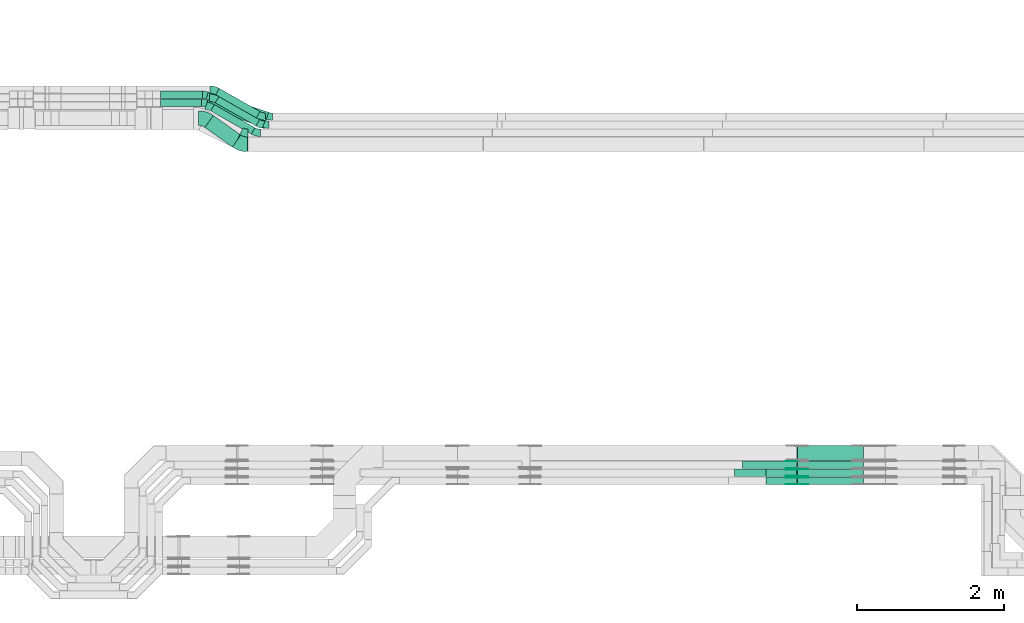
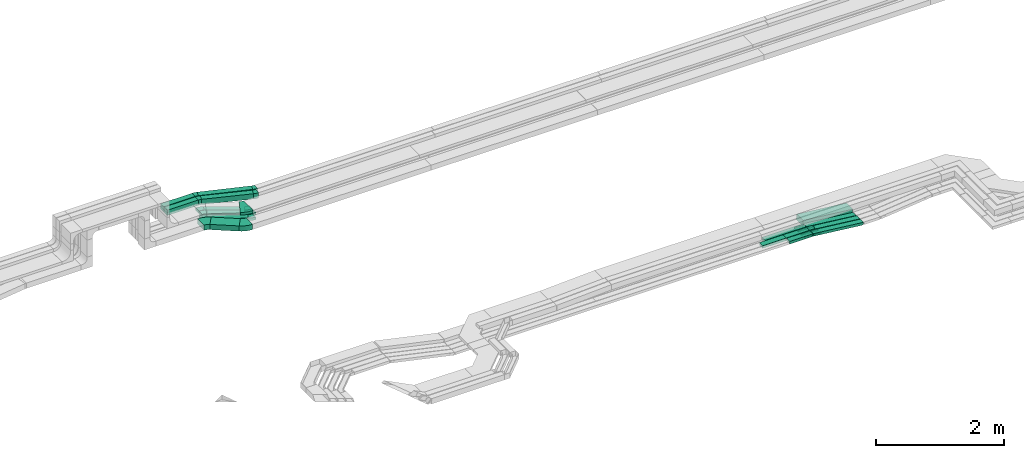
# One storey, part 18 of 33: 23 flow fittings, 16 flow segments.
"""IFC2X3 building model written with IfcOpenShell, lengths in millimetres."""

import ifcopenshell
import ifcopenshell.guid

model = None  # the IFC model being written
_history = None  # IfcOwnerHistory: only IFC2X3 demands one
_inside = {}  # id of a spatial element -> (the spatial element, [elements in it])
_under = {}  # id of a project, library or spatial element -> (it, [spatial elements below it])
_declared = {}  # id of a project -> (the project, [libraries it declares])
_typed = {}  # id of a type object -> (the type object, [elements of that type])
_made_of = {}  # id of a material, layer set ... -> (it, [elements and type objects made of it])


def new_model(schema):
    """Start an empty IFC model of exactly this schema.

    Asked for "IFC4X3", IfcOpenShell would pick the latest addendum, in which some entities
    have other attributes; the version numbers below select the first issue.
    IFC2X3 requires an IfcOwnerHistory on every rooted entity: one is made here for all.
    """
    global model, _history
    if schema == "IFC4X3":
        model = ifcopenshell.file(schema_version=(4, 3, 0, 0))
    else:
        model = ifcopenshell.file(schema=schema)
    _inside.clear()
    _under.clear()
    _declared.clear()
    _typed.clear()
    _made_of.clear()
    _history = None
    if model.schema == "IFC2X3":
        org = make("IfcOrganization", Name="unknown")
        user = make(
            "IfcPersonAndOrganization",
            ThePerson=make("IfcPerson", FamilyName="unknown"),
            TheOrganization=org,
        )
        app = make(
            "IfcApplication",
            ApplicationDeveloper=org,
            Version="unknown",
            ApplicationFullName="unknown",
            ApplicationIdentifier="unknown",
        )
        _history = make(
            "IfcOwnerHistory",
            OwningUser=user,
            OwningApplication=app,
            ChangeAction="ADDED",
            CreationDate=0,
        )
    return model


def make(cls, **values):
    """One entity of the class cls with the attributes given. An attribute that is None is left unset."""
    return model.create_entity(
        cls, **{name: value for name, value in values.items() if value is not None}
    )


def entity(cls, *values):
    """Any entity or typed value of the class cls, its attributes in the order of the schema. None: left unset."""
    e = model.create_entity(cls)
    for i, value in enumerate(values):
        if value is not None:
            e[i] = value
    return e


def rooted(cls, **values):
    """An entity with a GlobalId (a new one), such as an element, a storey or a relation."""
    return make(cls, GlobalId=ifcopenshell.guid.new(), OwnerHistory=_history, **values)


def si_unit(unit_type, name, prefix=None):
    """IfcSIUnit, for example si_unit("LENGTHUNIT", "METRE", prefix="MILLI")."""
    return make("IfcSIUnit", UnitType=unit_type, Prefix=prefix, Name=name)


def converted_unit(unit_type, name, factor, base, dimensions=None, offset=None):
    """IfcConversionBasedUnit, such as the inch: factor (a typed value) times the base unit."""
    return make(
        "IfcConversionBasedUnit"
        if offset is None
        else "IfcConversionBasedUnitWithOffset",
        ConversionOffset=offset,
        Dimensions=None
        if dimensions is None
        else entity("IfcDimensionalExponents", *dimensions),
        UnitType=unit_type,
        Name=name,
        ConversionFactor=make(
            "IfcMeasureWithUnit", ValueComponent=factor, UnitComponent=base
        ),
    )


def derived_unit(unit_type, elements):
    """IfcDerivedUnit: a product of units, each with its exponent."""
    return make(
        "IfcDerivedUnit",
        Elements=[
            make("IfcDerivedUnitElement", Unit=unit, Exponent=power)
            for unit, power in elements
        ],
        UnitType=unit_type,
    )


def assignment(units):
    """IfcUnitAssignment: the units of a project."""
    return None if units is None else make("IfcUnitAssignment", Units=units)


def point(xyz):
    """IfcCartesianPoint."""
    return None if xyz is None else make("IfcCartesianPoint", Coordinates=xyz)


def direction(xyz):
    """IfcDirection."""
    return None if xyz is None else make("IfcDirection", DirectionRatios=xyz)


def frame(location, z_axis=None, x_axis=None):
    """IfcAxis2Placement3D, a coordinate frame: its origin and axes. An axis left out is left unset."""
    return make(
        "IfcAxis2Placement3D",
        Location=point(location),
        Axis=direction(z_axis),
        RefDirection=direction(x_axis),
    )


def frame_2d(location, x_axis=None):
    """IfcAxis2Placement2D, a coordinate frame in the plane: its origin and x axis."""
    return make(
        "IfcAxis2Placement2D", Location=point(location), RefDirection=direction(x_axis)
    )


def origin():
    """The frame at (0, 0, 0) with its axes left unset."""
    return frame((0.0, 0.0, 0.0))


def origin_2d_with_axis():
    """The frame at (0, 0) in the plane with the x axis (1, 0) written out."""
    return frame_2d((0.0, 0.0), x_axis=(1.0, 0.0))


def place(relative_to, where):
    """IfcLocalPlacement: puts the frame where relative to a parent placement (None: the world)."""
    return make(
        "IfcLocalPlacement", PlacementRelTo=relative_to, RelativePlacement=where
    )


def context(
    kind, dimensions, precision=None, world=None, true_north=None, identifier=None
):
    """IfcGeometricRepresentationContext, for example the 3D "Model" context."""
    return make(
        "IfcGeometricRepresentationContext",
        ContextIdentifier=identifier,
        ContextType=kind,
        CoordinateSpaceDimension=dimensions,
        Precision=precision,
        WorldCoordinateSystem=world,
        TrueNorth=true_north,
    )


def subcontext(parent, identifier, kind, view, scale=None):
    """IfcGeometricRepresentationSubContext, for example "Body" below "Model"."""
    return make(
        "IfcGeometricRepresentationSubContext",
        ContextIdentifier=identifier,
        ContextType=kind,
        ParentContext=parent,
        TargetScale=scale,
        TargetView=view,
    )


def project(units=None, contexts=None):
    """IfcProject with its units and contexts."""
    return rooted(
        "IfcProject",
        Name="project",
        RepresentationContexts=contexts,
        UnitsInContext=assignment(units),
    )


def spatial(cls, under=None, at=None, **own):
    """A site, building, storey or space (cls), placed at a placement, below another one or the project."""
    s = rooted(cls, ObjectPlacement=at, **own)
    if under is not None:
        _under.setdefault(under.id(), (under, []))[1].append(s)
    return s


def polyline(points):
    """IfcPolyline through the points."""
    return make("IfcPolyline", Points=[point(p) for p in points])


def circle_curve(where, radius):
    """IfcCircle in the frame where."""
    return make("IfcCircle", Position=where, Radius=radius)


def parameter(value):
    """IfcParameterValue: where a trimmed curve begins or ends, as a parameter of its basis curve."""
    return model.create_entity("IfcParameterValue", value)


def trimmed(basis, trim1, trim2, sense, master):
    """IfcTrimmedCurve: the piece of a basis curve between two trims."""
    return make(
        "IfcTrimmedCurve",
        BasisCurve=basis,
        Trim1=trim1,
        Trim2=trim2,
        SenseAgreement=sense,
        MasterRepresentation=master,
    )


def segment(curve, same_sense, transition):
    """IfcCompositeCurveSegment."""
    return make(
        "IfcCompositeCurveSegment",
        Transition=transition,
        SameSense=same_sense,
        ParentCurve=curve,
    )


def composite_curve(segments, self_intersect=None):
    """IfcCompositeCurve: segments joined end to end."""
    return make("IfcCompositeCurve", Segments=segments, SelfIntersect=self_intersect)


def profile(cls, at=None, kind="AREA", **sizes):
    """A parametric profile (cls). Its sizes go by their IFC names, for example OverallWidth=200.0."""
    return make(cls, ProfileType=kind, Position=at, **sizes)


def rectangle(**sizes):
    """IfcRectangleProfileDef."""
    return profile("IfcRectangleProfileDef", **sizes)


def outline(outer, holes=None, kind="AREA"):
    """IfcArbitraryClosedProfileDef: a profile drawn as a closed curve; with holes, ...WithVoids."""
    if holes is None:
        return make("IfcArbitraryClosedProfileDef", ProfileType=kind, OuterCurve=outer)
    return make(
        "IfcArbitraryProfileDefWithVoids",
        ProfileType=kind,
        OuterCurve=outer,
        InnerCurves=holes,
    )


def extrude(swept, where, along, depth):
    """IfcExtrudedAreaSolid: the profile swept, set in the frame where, extruded along a direction by depth."""
    return make(
        "IfcExtrudedAreaSolid",
        SweptArea=swept,
        Position=where,
        ExtrudedDirection=direction(along),
        Depth=depth,
    )


def shape(context_of_items, identifier, shape_type, items):
    """IfcShapeRepresentation: the items that make up one representation, for example the "Body"."""
    return make(
        "IfcShapeRepresentation",
        ContextOfItems=context_of_items,
        RepresentationIdentifier=identifier,
        RepresentationType=shape_type,
        Items=items,
    )


def source(mapping_origin, context_of_items, identifier, shape_type, items):
    """IfcRepresentationMap: a shape defined once, which mapped items show again and again."""
    return make(
        "IfcRepresentationMap",
        MappingOrigin=mapping_origin,
        MappedRepresentation=shape(context_of_items, identifier, shape_type, items),
    )


def transform(
    local_origin,
    x_axis=None,
    y_axis=None,
    z_axis=None,
    scale=None,
    scale2=None,
    scale3=None,
    uniform=True,
):
    """IfcCartesianTransformationOperator3D, or its non-uniform kind. x_axis, y_axis, z_axis: its Axis1, 2, 3."""
    if uniform:
        return make(
            "IfcCartesianTransformationOperator3D",
            Axis1=direction(x_axis),
            Axis2=direction(y_axis),
            LocalOrigin=point(local_origin),
            Scale=scale,
            Axis3=direction(z_axis),
        )
    return make(
        "IfcCartesianTransformationOperator3DnonUniform",
        Axis1=direction(x_axis),
        Axis2=direction(y_axis),
        LocalOrigin=point(local_origin),
        Scale=scale,
        Axis3=direction(z_axis),
        Scale2=scale2,
        Scale3=scale3,
    )


def mapped(mapping_source, mapping_target):
    """IfcMappedItem: shows the shape of a source again, moved by a transform."""
    return make(
        "IfcMappedItem", MappingSource=mapping_source, MappingTarget=mapping_target
    )


def material(Name=None, Category=None):
    """IfcMaterial."""
    return make("IfcMaterial", Name=Name, Category=Category)


def made_of(thing, what):
    """Note that an element or type object is made of a material, layer set ...; save() writes the relation."""
    if what is not None:
        _made_of.setdefault(what.id(), (what, []))[1].append(thing)
    return thing


def type_object(cls, material=None, **own):
    """A type object (cls), such as IfcWallType, which elements share."""
    return made_of(rooted(cls, **own), material)


def type_shapes(of_type, sources):
    """Give a type object the sources (RepresentationMaps) that its elements show as mapped items."""
    of_type.RepresentationMaps = sources


def element(
    cls,
    number,
    at=None,
    inside=None,
    cuts=None,
    type_object=None,
    material=None,
    context=None,
    identifier="Body",
    shape_type=None,
    held_by="IfcProductDefinitionShape",
    body=None,
    shapes=None,
    **own,
):
    """One element of the class cls, such as IfcWall. Its Tag is "e" and its number.

    at: its placement. inside: the storey or other place that contains it. cuts: it is an
    opening in that element (IfcRelVoidsElement). A single representation is given by context,
    identifier, shape_type and body (its items); several are given by shapes. held_by: the class
    of the entity that holds the representations. save() writes the other relations.
    """
    e = rooted(cls, Tag="e%d" % number, ObjectPlacement=at, **own)
    if body is not None:
        shapes = [shape(context, identifier, shape_type, body)]
    if shapes is not None:
        e.Representation = make(held_by, Representations=shapes)
    if inside is not None:
        _inside.setdefault(inside.id(), (inside, []))[1].append(e)
    if cuts is not None:
        rooted(
            "IfcRelVoidsElement", RelatingBuildingElement=cuts, RelatedOpeningElement=e
        )
    if type_object is not None:
        _typed.setdefault(type_object.id(), (type_object, []))[1].append(e)
    return made_of(e, material)


def aggregate(whole, parts):
    """IfcRelAggregates: a whole, such as a stair, and the parts it consists of."""
    return rooted("IfcRelAggregates", RelatingObject=whole, RelatedObjects=parts)


def save(model, path):
    """Write the relations noted so far, then the file.

    IfcRelAggregates (storeys below a building ...), IfcRelContainedInSpatialStructure (elements
    in a storey), IfcRelDefinesByType, IfcRelAssociatesMaterial and IfcRelDeclares: one each for
    every whole, place, type object, material and project.
    """
    for whole, parts in _under.values():
        aggregate(whole, parts)
    for where, things in _inside.values():
        rooted(
            "IfcRelContainedInSpatialStructure",
            RelatedElements=things,
            RelatingStructure=where,
        )
    for kind, things in _typed.values():
        rooted("IfcRelDefinesByType", RelatedObjects=things, RelatingType=kind)
    for what, things in _made_of.values():
        rooted("IfcRelAssociatesMaterial", RelatedObjects=things, RelatingMaterial=what)
    for by, libraries in _declared.values():
        rooted("IfcRelDeclares", RelatingContext=by, RelatedDefinitions=libraries)
    model.write(path)


model = new_model("IFC2X3")

# Units and contexts
model_context = context("Model", 3, precision=0.01, world=origin(), true_north=direction((6.12303176911189e-17, 1.0)))
body_context = subcontext(model_context, "Body", "Model", "MODEL_VIEW")
ifc_project = project(units=[si_unit("LENGTHUNIT", "METRE", prefix="MILLI"), si_unit("AREAUNIT", "SQUARE_METRE"), si_unit("VOLUMEUNIT", "CUBIC_METRE"), converted_unit("PLANEANGLEUNIT", "DEGREE", entity("IfcRatioMeasure", 0.0174532925199433), si_unit("PLANEANGLEUNIT", "RADIAN"), dimensions=[0, 0, 0, 0, 0, 0, 0]), si_unit("MASSUNIT", "GRAM", prefix="KILO"), derived_unit("MASSDENSITYUNIT", [(si_unit("MASSUNIT", "GRAM", prefix="KILO"), 1), (si_unit("LENGTHUNIT", "METRE"), -3)]), derived_unit("MOMENTOFINERTIAUNIT", [(si_unit("LENGTHUNIT", "METRE"), 4)]), si_unit("TIMEUNIT", "SECOND"), si_unit("FREQUENCYUNIT", "HERTZ"), si_unit("THERMODYNAMICTEMPERATUREUNIT", "DEGREE_CELSIUS"), derived_unit("THERMALTRANSMITTANCEUNIT", [(si_unit("MASSUNIT", "GRAM", prefix="KILO"), 1), (si_unit("THERMODYNAMICTEMPERATUREUNIT", "KELVIN"), -1), (si_unit("TIMEUNIT", "SECOND"), -3)]), derived_unit("VOLUMETRICFLOWRATEUNIT", [(si_unit("LENGTHUNIT", "METRE"), 3), (si_unit("TIMEUNIT", "SECOND"), -1)]), derived_unit("MASSFLOWRATEUNIT", [(si_unit("MASSUNIT", "GRAM", prefix="KILO"), 1), (si_unit("TIMEUNIT", "SECOND"), -1)]), derived_unit("ROTATIONALFREQUENCYUNIT", [(si_unit("TIMEUNIT", "SECOND"), -1)]), si_unit("ELECTRICCURRENTUNIT", "AMPERE"), si_unit("ELECTRICVOLTAGEUNIT", "VOLT"), si_unit("POWERUNIT", "WATT"), si_unit("FORCEUNIT", "NEWTON", prefix="KILO"), si_unit("ILLUMINANCEUNIT", "LUX"), si_unit("LUMINOUSFLUXUNIT", "LUMEN"), si_unit("LUMINOUSINTENSITYUNIT", "CANDELA"), derived_unit("USERDEFINED", [(si_unit("MASSUNIT", "GRAM", prefix="KILO"), -1), (si_unit("LENGTHUNIT", "METRE"), -2), (si_unit("TIMEUNIT", "SECOND"), 3), (si_unit("LUMINOUSFLUXUNIT", "LUMEN"), 1)]), derived_unit("LINEARVELOCITYUNIT", [(si_unit("LENGTHUNIT", "METRE"), 1), (si_unit("TIMEUNIT", "SECOND"), -1)]), si_unit("PRESSUREUNIT", "PASCAL"), derived_unit("USERDEFINED", [(si_unit("LENGTHUNIT", "METRE"), -2), (si_unit("MASSUNIT", "GRAM", prefix="KILO"), 1), (si_unit("TIMEUNIT", "SECOND"), -2)]), derived_unit("LINEARFORCEUNIT", [(si_unit("MASSUNIT", "GRAM", prefix="KILO"), 1), (si_unit("LENGTHUNIT", "METRE"), 1), (si_unit("TIMEUNIT", "SECOND"), -2), (si_unit("LENGTHUNIT", "METRE"), -1)]), derived_unit("PLANARFORCEUNIT", [(si_unit("MASSUNIT", "GRAM", prefix="KILO"), 1), (si_unit("LENGTHUNIT", "METRE"), 1), (si_unit("TIMEUNIT", "SECOND"), -2), (si_unit("LENGTHUNIT", "METRE"), -2)])], contexts=[model_context])

# Site, building, storey
site_placement = place(None, frame((0.0, -0.00077364408347762, 0.0)))
site = spatial("IfcSite", under=ifc_project, at=site_placement, CompositionType="ELEMENT")
building_placement = place(site_placement, origin())
building = spatial("IfcBuilding", under=site, at=building_placement, CompositionType="ELEMENT")
storey_placement = place(building_placement, frame((0.0, 0.0, 8100.0)))
storey = spatial("IfcBuildingStorey", under=building, at=storey_placement, CompositionType="ELEMENT", Elevation=8100.0)

# Flow segments
cable_carrier_segment_type = type_object("IfcCableCarrierSegmentType", PredefinedType="CABLETRAYSEGMENT")
flow_segment_1_placement = place(storey_placement, frame((39414.2553602729, 9864.99855346682, 2544.92549664435)))
element("IfcFlowSegment", 1, at=flow_segment_1_placement, inside=storey, type_object=cable_carrier_segment_type, context=body_context, shape_type="SweptSolid", body=[
    extrude(rectangle(XDim=734.864056960746, YDim=99.9999999999989, at=frame_2d((4.32009983342141e-12, 0.0), x_axis=(1.0, 0.0))), frame((367.432028480377, 50.0, 0.0)), (0.0, 0.0, 1.0), 50.0000000000016),
])
flow_segment_2_placement = place(storey_placement, frame((39304.2553602729, 9754.99855346681, 2546.31908538351)))
element("IfcFlowSegment", 2, at=flow_segment_2_placement, inside=storey, type_object=cable_carrier_segment_type, context=body_context, shape_type="SweptSolid", body=[
    extrude(rectangle(XDim=948.992857325044, YDim=99.9999999999989, at=frame_2d((-4.32009983342141e-12, 0.0), x_axis=(1.0, 0.0))), frame((474.496428662526, 50.0, 0.0)), (0.0, 0.0, 1.0), 50.0000000000016),
])
flow_segment_3_placement = place(storey_placement, frame((32094.1810027056, 14239.3490417928, 2548.87698397102)))
element("IfcFlowSegment", 3, at=flow_segment_3_placement, inside=storey, type_object=cable_carrier_segment_type, context=body_context, shape_type="SweptSolid", body=[
    extrude(rectangle(XDim=458.510292454723, YDim=200.000000000002, at=frame_2d((-1.76214598468505e-12, -1.25766064229538e-12), x_axis=(1.0, 0.0))), frame((244.909500939085, 214.039689258386, 0.0), z_axis=(0.0, 0.0, 1.0), x_axis=(-0.816364917109081, 0.577536424923557, 0.0)), (0.0, 0.0, 1.0), 99.9999999999989),
])
flow_segment_4_placement = place(storey_placement, frame((32235.1195390876, 14525.3656413056, 2548.34838425104)))
element("IfcFlowSegment", 4, at=flow_segment_4_placement, inside=storey, type_object=cable_carrier_segment_type, context=body_context, shape_type="SweptSolid", body=[
    extrude(rectangle(XDim=637.297455532549, YDim=100.000000000004, at=frame_2d((5.40012479177676e-13, -9.48574552239734e-13), x_axis=(1.0, 0.0))), frame((301.790593880873, 200.802099136024, 0.0), z_axis=(0.0, 0.0, 1.0), x_axis=(-0.869625227484752, 0.493712430187952, 0.0)), (0.0, 0.0, 1.0), 50.0000000000016),
])
flow_segment_5_placement = place(storey_placement, frame((32172.6692264652, 14415.3656413056, 2548.879926104)))
element("IfcFlowSegment", 5, at=flow_segment_5_placement, inside=storey, type_object=cable_carrier_segment_type, context=body_context, shape_type="SweptSolid", body=[
    extrude(rectangle(XDim=637.297455532608, YDim=99.9999999999995, at=frame_2d((5.40012479177676e-13, -9.41469124882133e-13), x_axis=(1.0, 0.0))), frame((301.790593880899, 200.802099136031, 0.0), z_axis=(0.0, 0.0, 1.0), x_axis=(-0.869625227484766, 0.493712430187927, 0.0)), (0.0, 0.0, 1.0), 50.0000000000016),
])
flow_segment_6_placement = place(storey_placement, frame((32240.5963756525, 14635.3656413056, 2548.86724903677)))
element("IfcFlowSegment", 6, at=flow_segment_6_placement, inside=storey, type_object=cable_carrier_segment_type, context=body_context, shape_type="SweptSolid", body=[
    extrude(rectangle(XDim=637.297455532466, YDim=100.0, at=frame_2d((1.90425453183707e-12, 1.07647224467655e-12), x_axis=(1.0, 0.0))), frame((301.790593880838, 200.802099136011, 0.0), z_axis=(0.0, 0.0, 1.0), x_axis=(-0.869625227484736, 0.49371243018798, 0.0)), (0.0, 0.0, 1.0), 50.0000000000016),
])
flow_segment_7_placement = place(storey_placement, frame((32109.5124104278, 14615.6591121141, 2855.0)))
element("IfcFlowSegment", 7, at=flow_segment_7_placement, inside=storey, type_object=cable_carrier_segment_type, context=body_context, shape_type="SweptSolid", body=[
    extrude(rectangle(XDim=865.944698440222, YDim=100.000000000001, at=frame_2d((2.41584530158434e-12, -3.41060513164848e-13), x_axis=(1.0, 0.0))), frame((426.300961317753, 185.508628327534, 0.0), z_axis=(0.0, 0.0, 1.0), x_axis=(0.947752520609184, -0.319006519806318, 0.0)), (0.0, 0.0, 1.0), 99.9999999999989),
])
flow_segment_8_placement = place(storey_placement, frame((31491.4130823037, 14900.0572451367, 2855.0)))
element("IfcFlowSegment", 8, at=flow_segment_8_placement, inside=storey, type_object=cable_carrier_segment_type, context=body_context, shape_type="SweptSolid", body=[
    extrude(rectangle(XDim=568.300597632481, YDim=99.9999999999989, at=frame_2d((0.0, 1.08357767203415e-12), x_axis=(1.0, 0.0))), frame((284.15029881624, 50.0, 0.0)), (0.0, 0.0, 1.0), 99.9999999999989),
])
flow_segment_9_placement = place(storey_placement, frame((32102.1575916921, 14506.8072977071, 2855.0)))
element("IfcFlowSegment", 9, at=flow_segment_9_placement, inside=storey, type_object=cable_carrier_segment_type, context=body_context, shape_type="SweptSolid", body=[
    extrude(rectangle(XDim=826.032338291808, YDim=99.9999999999999, at=origin_2d_with_axis()), frame((406.171515449329, 184.36044273458, 0.0), z_axis=(0.0, 0.0, 1.0), x_axis=(0.943212511924906, -0.332189941672396, 0.0)), (0.0, 0.0, 1.0), 99.9999999999989),
])
flow_segment_10_placement = place(storey_placement, frame((31491.4130823037, 14790.0572451367, 2855.0)))
element("IfcFlowSegment", 10, at=flow_segment_10_placement, inside=storey, type_object=cable_carrier_segment_type, context=body_context, shape_type="SweptSolid", body=[
    extrude(rectangle(XDim=558.972805625544, YDim=99.9999999999989, at=frame_2d((0.0, -1.08357767203415e-12), x_axis=(1.0, 0.0))), frame((279.486402812772, 50.0, 0.0)), (0.0, 0.0, 1.0), 99.9999999999989),
])
flow_segment_11_placement = place(storey_placement, frame((40151.5523091819, 9644.99855346679, 2447.10523946025)))
element("IfcFlowSegment", 11, at=flow_segment_11_placement, inside=storey, type_object=cable_carrier_segment_type, context=body_context, shape_type="SweptSolid", body=[
    extrude(rectangle(XDim=50.0000000000012, YDim=100.000000000001, at=origin_2d_with_axis()), frame((2.74331759634265, 50.0, 124.2429877633), z_axis=(0.993961132894519, 0.0, -0.109732703853703), x_axis=(0.109732703853703, 0.0, 0.993961132894519)), (0.0, 0.0, 1.0), 905.782469130237),
])
flow_segment_12_placement = place(storey_placement, frame((39730.3894172285, 9644.99855346679, 2546.63308707346)))
element("IfcFlowSegment", 12, at=flow_segment_12_placement, inside=storey, type_object=cable_carrier_segment_type, context=body_context, shape_type="SweptSolid", body=[
    extrude(rectangle(XDim=418.730000005077, YDim=100.000000000001, at=frame_2d((-4.33431068813661e-12, 0.0), x_axis=(1.0, 0.0))), frame((209.365000002543, 50.0, 0.0), z_axis=(0.0, 0.0, 1.0), x_axis=(-1.0, 0.0, 0.0)), (0.0, 0.0, 1.0), 50.0000000000016),
])
flow_segment_13_placement = place(storey_placement, frame((40151.5145270794, 9754.99855346682, 2446.75883726185)))
element("IfcFlowSegment", 13, at=flow_segment_13_placement, inside=storey, type_object=cable_carrier_segment_type, context=body_context, shape_type="SweptSolid", body=[
    extrude(rectangle(XDim=50.0000000000012, YDim=99.9999999999989, at=origin_2d_with_axis()), frame((2.74331759634265, 50.0, 124.247158884456), z_axis=(0.993961132894519, 0.0, -0.109732703853703), x_axis=(0.109732703853703, 0.0, 0.993961132894519)), (0.0, 0.0, 1.0), 905.820480780093),
])
flow_segment_14_placement = place(storey_placement, frame((39730.3894172285, 9754.99855346682, 2546.29085599621)))
element("IfcFlowSegment", 14, at=flow_segment_14_placement, inside=storey, type_object=cable_carrier_segment_type, context=body_context, shape_type="SweptSolid", body=[
    extrude(rectangle(XDim=418.692217902529, YDim=99.9999999999989, at=frame_2d((-4.33431068813661e-12, 0.0), x_axis=(1.0, 0.0))), frame((209.346108951269, 50.0, 0.0), z_axis=(0.0, 0.0, 1.0), x_axis=(-1.0, 0.0, 0.0)), (0.0, 0.0, 1.0), 50.0000000000038),
])
flow_segment_15_placement = place(storey_placement, frame((40151.5523091819, 9864.99855346682, 2445.41821058217)))
element("IfcFlowSegment", 15, at=flow_segment_15_placement, inside=storey, type_object=cable_carrier_segment_type, context=body_context, shape_type="SweptSolid", body=[
    extrude(rectangle(XDim=50.0000000000012, YDim=99.9999999999989, at=origin_2d_with_axis()), frame((2.74331759633399, 50.0, 124.222426212274), z_axis=(0.993961132894519, 0.0, -0.109732703853703), x_axis=(0.109732703853703, 0.0, 0.993961132894519)), (0.0, 0.0, 1.0), 905.595090615417),
])
flow_segment_16_placement = place(storey_placement, frame((40151.5684003383, 9974.9985534668, 2447.844082236)))
element("IfcFlowSegment", 16, at=flow_segment_16_placement, inside=storey, type_object=cable_carrier_segment_type, context=body_context, shape_type="SweptSolid", body=[
    extrude(rectangle(XDim=99.9999999999982, YDim=200.000000000002, at=origin_2d_with_axis()), frame((5.48663519269396, 100.0, 148.484518447362), z_axis=(0.993961132894518, 0.0, -0.109732703853708), x_axis=(0.109732703853708, 0.0, 0.993961132894518)), (0.0, 0.0, 1.0), 900.246310655869),
])

# Flow fittings
ifc_material_1 = material()
cable_carrier_fitting_type_1 = type_object("IfcCableCarrierFittingType", Name="470_DKC_S5_Variable Angle Elbow 0-45:-", PredefinedType="NOTDEFINED", material=ifc_material_1)
shared_shape_1 = source(origin(), body_context, "Body", "SweptSolid", [
    extrude(outline(composite_curve([segment(polyline([(-67.6616049684268, -165.75060662875), (-66.6616049684255, -165.75060662875)]), True, "CONTINUOUS"), segment(trimmed(circle_curve(frame_2d((-66.6616049684336, 284.24939337125), x_axis=(0.0, -1.0)), 450.0), [parameter(0.0)], [parameter(26.3967564439115)], True, "PARAMETER"), True, "CONTINUOUS"), segment(polyline([(133.401407239414, -118.83222509618), (134.297144169341, -118.387640624607)]), True, "CONTINUOUS"), segment(polyline([(134.297144169341, -118.387640624607), (0.921802697443936, 150.33343835368)]), True, "CONTINUOUS"), segment(polyline([(0.921802697443919, 150.33343835368), (0.0260657675154811, 149.888853882107)]), True, "CONTINUOUS"), segment(trimmed(circle_curve(frame_2d((-66.6616049684336, 284.24939337125), x_axis=(0.0, -1.0)), 150.0), [parameter(0.0)], [parameter(26.3967564439115)], True, "PARAMETER"), False, "CONTINUOUS"), segment(polyline([(-66.6616049684306, 134.24939337125), (-67.6616049684319, 134.24939337125)]), True, "CONTINUOUS"), segment(polyline([(-67.6616049684319, 134.24939337125), (-67.6616049684268, -165.75060662875)]), True, "CONTINUOUS")], self_intersect=False)), frame((-3.69380108306741, 15.7506066287408, -25.0)), (0.0, 0.0, 1.0), 49.999999999999),
])
type_shapes(cable_carrier_fitting_type_1, [shared_shape_1])
flow_fitting_placement = place(storey_placement, frame((32612.1430823088, 14332.2782357472, 2879.49733895749), z_axis=(0.0, 0.0, 1.0), x_axis=(0.895736929927626, -0.444584471572987, 0.0)))
element("IfcFlowFitting", 17, at=flow_fitting_placement, inside=storey, type_object=cable_carrier_fitting_type_1, material=ifc_material_1, Name="470_DKC_S5_Variable Angle Elbow 0-45:-", ObjectType="470_DKC_S5_Variable Angle Elbow 0-45:-", context=body_context, shape_type="MappedRepresentation", body=[
    mapped(shared_shape_1, transform((0.0, 0.0, 0.0), scale=1.0)),
])
cable_carrier_fitting_type_2 = type_object("IfcCableCarrierFittingType", Name="470_DKC_S5_Variable Angle Elbow 0-45:-", PredefinedType="NOTDEFINED", material=ifc_material_1)
shared_shape_2 = source(origin(), body_context, "Body", "SweptSolid", [
    extrude(outline(composite_curve([segment(polyline([(-73.1461443447185, -123.098769467593), (-72.1461443447173, -123.098769467593)]), True, "CONTINUOUS"), segment(trimmed(circle_curve(frame_2d((-72.1461443447177, 226.901230532407), x_axis=(0.0, -1.0)), 350.0), [parameter(0.0)], [parameter(35.2774537887441)], True, "PARAMETER"), True, "CONTINUOUS"), segment(polyline([(129.991604378515, -58.8264904557794), (130.807969295625, -58.2489540308556)]), True, "CONTINUOUS"), segment(polyline([(130.807969295625, -58.2489540308556), (15.3006843109194, 105.024029390965)]), True, "CONTINUOUS"), segment(polyline([(15.3006843109194, 105.024029390965), (14.4843193938107, 104.446492966041)]), True, "CONTINUOUS"), segment(trimmed(circle_curve(frame_2d((-72.1461443447177, 226.901230532407), x_axis=(0.0, -1.0)), 150.0), [parameter(0.0)], [parameter(35.2774537887441)], True, "PARAMETER"), False, "CONTINUOUS"), segment(polyline([(-72.1461443447173, 76.9012305324071), (-73.1461443447185, 76.9012305324071)]), True, "CONTINUOUS"), segment(polyline([(-73.1461443447185, 76.9012305324071), (-73.1461443447185, -123.098769467593)]), True, "CONTINUOUS")], self_intersect=False)), frame((-7.34454878134336, 23.0987694675847, -50.0)), (0.0, 0.0, 1.0), 100.0),
])
type_shapes(cable_carrier_fitting_type_2, [shared_shape_2])
for number, where, z_axis, x_axis, name in (
    (18, (32591.9561401134, 14274.499226356, 2598.87698397102), (0.0, 0.0, 1.0), (0.816364917109106, -0.577536424923522, 0.0), "470_DKC_S5_Variable Angle Elbow 0-45:-"),
    (19, (32086.2248671761, 14632.2782357463, 2598.87698397102), (0.0, 0.0, 1.0), (-0.81636491710906, 0.577536424923586, 0.0), "470_DKC_S5_Variable Angle Elbow 0-45:-"),
):
    element("IfcFlowFitting", number, at=place(storey_placement, frame(where, z_axis=z_axis, x_axis=x_axis)), inside=storey, type_object=cable_carrier_fitting_type_2, material=ifc_material_1, Name=name, ObjectType="470_DKC_S5_Variable Angle Elbow 0-45:-", context=body_context, shape_type="MappedRepresentation", body=[
        mapped(shared_shape_2, transform((0.0, 0.0, 0.0), scale=1.0)),
    ])
cable_carrier_fitting_type_3 = type_object("IfcCableCarrierFittingType", Name="470_DKC_S5_Variable Angle Elbow 0-45:-", PredefinedType="NOTDEFINED", material=ifc_material_1)
shared_shape_3 = source(origin(), body_context, "Body", "SweptSolid", [
    extrude(outline(composite_curve([segment(polyline([(-50.3386493256676, -63.160905359072), (-49.3386493256662, -63.160905359072)]), True, "CONTINUOUS"), segment(trimmed(circle_curve(frame_2d((-49.3386493256667, 186.839094640928), x_axis=(0.0, -1.0)), 250.0), [parameter(0.0)], [parameter(29.5848823129969)], True, "PARAMETER"), True, "CONTINUOUS"), segment(polyline([(74.089458221322, -30.5672122302595), (74.959083448807, -30.0734998000714)]), True, "CONTINUOUS"), segment(polyline([(74.959083448807, -30.0734998000715), (25.5878404300111, 56.8890229484032)]), True, "CONTINUOUS"), segment(polyline([(25.5878404300111, 56.8890229484032), (24.7182152025265, 56.3953105182154)]), True, "CONTINUOUS"), segment(trimmed(circle_curve(frame_2d((-49.3386493256667, 186.839094640928), x_axis=(0.0, -1.0)), 150.0), [parameter(0.0)], [parameter(29.5848823129969)], True, "PARAMETER"), False, "CONTINUOUS"), segment(polyline([(-49.3386493256662, 36.8390946409279), (-50.3386493256676, 36.8390946409279)]), True, "CONTINUOUS"), segment(polyline([(-50.3386493256676, 36.8390946409279), (-50.3386493256676, -63.160905359072)]), True, "CONTINUOUS")], self_intersect=False)), frame((-3.47540377224392, 13.1609053590639, -25.0)), (0.0, 0.0, 1.0), 50.0),
])
type_shapes(cable_carrier_fitting_type_3, [shared_shape_3])
for number, where, z_axis, x_axis, name in (
    (20, (32213.0071024299, 14910.0572451366, 2573.34838425104), (0.0, 0.0, 1.0), (-0.869625227484751, 0.493712430187954, 0.0), "470_DKC_S5_Variable Angle Elbow 0-45:-"),
    (21, (32150.5567898075, 14800.0572451366, 2573.87992610401), (0.0, 0.0, 1.0), (-0.869625227484763, 0.493712430187932, 0.0), "470_DKC_S5_Variable Angle Elbow 0-45:-"),
    (22, (32798.3628508848, 14432.2782357466, 2573.87992610401), (0.0, 0.0, 1.0), (0.869625227484763, -0.493712430187932, 0.0), "470_DKC_S5_Variable Angle Elbow 0-45:-"),
    (23, (32866.2900000719, 14652.2782357466, 2573.86724903678), (0.0, 0.0, 1.0), (0.869625227484745, -0.493712430187964, 0.0), "470_DKC_S5_Variable Angle Elbow 0-45:-"),
    (24, (32218.4839389948, 15020.0572451366, 2573.86724903678), (0.0, 0.0, 1.0), (-0.869625227484732, 0.493712430187987, 0.0), "470_DKC_S5_Variable Angle Elbow 0-45:-"),
    (25, (32860.8131635071, 14542.2782357466, 2573.34838425104), (0.0, 0.0, 1.0), (0.869625227484747, -0.49371243018796, 0.0), "470_DKC_S5_Variable Angle Elbow 0-45:-"),
):
    element("IfcFlowFitting", number, at=place(storey_placement, frame(where, z_axis=z_axis, x_axis=x_axis)), inside=storey, type_object=cable_carrier_fitting_type_3, material=ifc_material_1, Name=name, ObjectType="470_DKC_S5_Variable Angle Elbow 0-45:-", context=body_context, shape_type="MappedRepresentation", body=[
        mapped(shared_shape_3, transform((0.0, 0.0, 0.0), scale=1.0)),
    ])
cable_carrier_fitting_type_4 = type_object("IfcCableCarrierFittingType", Name="470_DKC_S5_Variable Angle Elbow 0-45:-", PredefinedType="NOTDEFINED", material=ifc_material_1)
shared_shape_4 = source(origin(), body_context, "Body", "SweptSolid", [
    extrude(outline(composite_curve([segment(polyline([(-32.8875901107843, -55.3044995690334), (-31.887590110783, -55.3044995690334)]), True, "CONTINUOUS"), segment(trimmed(circle_curve(frame_2d((-31.8875901107856, 194.695500430966), x_axis=(0.0, -1.0)), 250.0), [parameter(0.0)], [parameter(18.6028540575066)], True, "PARAMETER"), True, "CONTINUOUS"), segment(polyline([(47.8640398407955, -42.2426297213288), (48.8117923614045, -41.9236232015225)]), True, "CONTINUOUS"), segment(polyline([(48.8117923614045, -41.9236232015225), (16.9111403807724, 52.8516288593956)]), True, "CONTINUOUS"), segment(polyline([(16.9111403807724, 52.8516288593956), (15.963387860163, 52.5326223395892)]), True, "CONTINUOUS"), segment(trimmed(circle_curve(frame_2d((-31.8875901107856, 194.695500430966), x_axis=(0.0, -1.0)), 150.0), [parameter(0.0)], [parameter(18.6028540575066)], True, "PARAMETER"), False, "CONTINUOUS"), segment(polyline([(-31.8875901107839, 44.6955004309665), (-32.8875901107852, 44.6955004309665)]), True, "CONTINUOUS"), segment(polyline([(-32.8875901107852, 44.6955004309665), (-32.8875901107843, -55.3044995690334)]), True, "CONTINUOUS")], self_intersect=False)), frame((-0.868780776257499, 5.30449956902505, -50.0)), (0.0, 0.0, 1.0), 100.0),
])
type_shapes(cable_carrier_fitting_type_4, [shared_shape_4])
for number, where, z_axis, x_axis, name in (
    (26, (32093.4700508233, 14950.0572451367, 2905.0), (0.0, 0.0, 1.0), (-0.947752520609185, 0.319006519806315, 0.0), "470_DKC_S5_Variable Angle Elbow 0-45:-"),
    (27, (32978.1566926678, 14652.2782357467, 2905.0), (0.0, 0.0, 1.0), (0.947752520609181, -0.319006519806326, 0.0), "470_DKC_S5_Variable Angle Elbow 0-45:-"),
):
    element("IfcFlowFitting", number, at=place(storey_placement, frame(where, z_axis=z_axis, x_axis=x_axis)), inside=storey, type_object=cable_carrier_fitting_type_4, material=ifc_material_1, Name=name, ObjectType="470_DKC_S5_Variable Angle Elbow 0-45:-", context=body_context, shape_type="MappedRepresentation", body=[
        mapped(shared_shape_4, transform((0.0, 0.0, 0.0), scale=1.0)),
    ])
cable_carrier_fitting_type_5 = type_object("IfcCableCarrierFittingType", Name="470_DKC_S5_Variable Angle Elbow 0-45:-", PredefinedType="NOTDEFINED", material=ifc_material_1)
shared_shape_5 = source(origin(), body_context, "Body", "SweptSolid", [
    extrude(outline(composite_curve([segment(polyline([(-34.2047972952214, -55.7617962929279), (-33.2047972952201, -55.7617962929279)]), True, "CONTINUOUS"), segment(trimmed(circle_curve(frame_2d((-33.2047972952227, 194.238203707072), x_axis=(0.0, -1.0)), 250.0), [parameter(0.0)], [parameter(19.4017500514484)], True, "PARAMETER"), True, "CONTINUOUS"), segment(polyline([(49.8426881228788, -41.5649242741534), (50.7859006348036, -41.232734332481)]), True, "CONTINUOUS"), segment(polyline([(50.7859006348036, -41.232734332481), (17.5669064675632, 53.0885168600091)]), True, "CONTINUOUS"), segment(polyline([(17.5669064675632, 53.0885168600091), (16.6236939556382, 52.7563269183367)]), True, "CONTINUOUS"), segment(trimmed(circle_curve(frame_2d((-33.2047972952227, 194.238203707072), x_axis=(0.0, -1.0)), 150.0), [parameter(0.0)], [parameter(19.4017500514484)], True, "PARAMETER"), False, "CONTINUOUS"), segment(polyline([(-33.204797295221, 44.238203707072), (-34.2047972952223, 44.238203707072)]), True, "CONTINUOUS"), segment(polyline([(-34.2047972952223, 44.238203707072), (-34.2047972952214, -55.7617962929279)]), True, "CONTINUOUS")], self_intersect=False)), frame((-0.984972442649047, 5.76179629291953, -50.0)), (0.0, 0.0, 1.0), 100.0),
])
type_shapes(cable_carrier_fitting_type_5, [shared_shape_5])
for number, where, z_axis, x_axis, name in (
    (28, (32085.5756576672, 14840.0572451367, 2905.0), (0.0, 0.0, 1.0), (-0.943212511924905, 0.332189941672396, 0.0), "470_DKC_S5_Variable Angle Elbow 0-45:-"),
    (29, (32931.0825566156, 14542.2782357467, 2905.0), (0.0, 0.0, 1.0), (0.943212511924902, -0.332189941672405, 0.0), "470_DKC_S5_Variable Angle Elbow 0-45:-"),
):
    element("IfcFlowFitting", number, at=place(storey_placement, frame(where, z_axis=z_axis, x_axis=x_axis)), inside=storey, type_object=cable_carrier_fitting_type_5, material=ifc_material_1, Name=name, ObjectType="470_DKC_S5_Variable Angle Elbow 0-45:-", context=body_context, shape_type="MappedRepresentation", body=[
        mapped(shared_shape_5, transform((0.0, 0.0, 0.0), scale=1.0)),
    ])
ifc_material_2 = material(Name="G")
cable_carrier_fitting_type_6 = type_object("IfcCableCarrierFittingType", PredefinedType="NOTDEFINED", material=ifc_material_2)
shared_shape_6 = source(origin(), body_context, "Body", "SweptSolid", [
    extrude(outline(composite_curve([segment(trimmed(circle_curve(frame_2d((-44.5901162790698, 0.0), x_axis=(1.0, 0.0)), 12.5), [parameter(90.0000000000007)], [parameter(270.0)], True, "PARAMETER"), True, "CONTINUOUS"), segment(polyline([(-44.5901162790697, -12.5), (-33.0901162790698, -12.5)]), True, "CONTINUOUS"), segment(polyline([(-33.0901162790698, -12.5), (-31.2296511627907, -14.5)]), True, "CONTINUOUS"), segment(polyline([(-31.2296511627907, -14.5), (108.90988372093, -14.5)]), True, "CONTINUOUS"), segment(polyline([(108.90988372093, -14.5), (108.90988372093, 14.5)]), True, "CONTINUOUS"), segment(polyline([(108.90988372093, 14.5), (-31.2296511627907, 14.5)]), True, "CONTINUOUS"), segment(polyline([(-31.2296511627907, 14.5), (-33.0901162790698, 12.5)]), True, "CONTINUOUS"), segment(polyline([(-33.0901162790698, 12.5), (-44.5901162790699, 12.5)]), True, "CONTINUOUS")], self_intersect=False)), frame((44.5901162790698, 0.0, 0.0), z_axis=(0.0, 0.0, -1.0), x_axis=(1.0, 0.0, 0.0)), (0.0, 0.0, -1.0), 2.0),
])
type_shapes(cable_carrier_fitting_type_6, [shared_shape_6])
for number, where, z_axis, x_axis in (
    (30, (40151.7153602835, 9740.45855347695, 2571.63308707348), (0.0, 1.0, 0.0), (0.993961132894515, 0.0, -0.10973270385374)),
    (31, (40151.6775781809, 9850.45855347697, 2571.29085599623), (0.0, 1.0, 0.0), (0.993961132894515, 0.0, -0.10973270385374)),
    (32, (40151.7153602835, 9869.53855345666, 2569.92549664437), (0.0, -1.0, 0.0), (-1.0, 0.0, 0.0)),
):
    element("IfcFlowFitting", number, at=place(storey_placement, frame(where, z_axis=z_axis, x_axis=x_axis)), inside=storey, type_object=cable_carrier_fitting_type_6, material=ifc_material_2, context=body_context, shape_type="MappedRepresentation", body=[
        mapped(shared_shape_6, transform((0.0, 0.0, 0.0), scale=1.0)),
    ])
cable_carrier_fitting_type_7 = type_object("IfcCableCarrierFittingType", PredefinedType="NOTDEFINED", material=ifc_material_2)
shared_shape_7 = source(origin(), body_context, "Body", "SweptSolid", [
    extrude(outline(composite_curve([segment(trimmed(circle_curve(frame_2d((-44.5901162790697, 0.0), x_axis=(1.0, 0.0)), 12.5), [parameter(90.0000000000007)], [parameter(270.0)], True, "PARAMETER"), True, "CONTINUOUS"), segment(polyline([(-44.5901162790697, -12.5), (-33.0901162790697, -12.5)]), True, "CONTINUOUS"), segment(polyline([(-33.0901162790697, -12.5), (-31.2296511627907, -14.5)]), True, "CONTINUOUS"), segment(polyline([(-31.2296511627907, -14.5), (108.90988372093, -14.5)]), True, "CONTINUOUS"), segment(polyline([(108.90988372093, -14.5), (108.90988372093, 14.5)]), True, "CONTINUOUS"), segment(polyline([(108.90988372093, 14.5), (-31.2296511627907, 14.5)]), True, "CONTINUOUS"), segment(polyline([(-31.2296511627907, 14.5), (-33.0901162790698, 12.5)]), True, "CONTINUOUS"), segment(polyline([(-33.0901162790698, 12.5), (-44.5901162790699, 12.5)]), True, "CONTINUOUS")], self_intersect=False)), frame((44.5901162790697, 0.0, 0.0)), (0.0, 0.0, 1.0), 2.0),
])
type_shapes(cable_carrier_fitting_type_7, [shared_shape_7])
for number, where, z_axis, x_axis in (
    (33, (40151.7153602835, 9649.53855345663, 2571.63308707348), (0.0, -1.0, 0.0), (0.993961132894515, 0.0, -0.10973270385374)),
    (34, (40151.6775781809, 9759.53855345666, 2571.29085599624), (0.0, -1.0, 0.0), (0.993961132894515, 0.0, -0.10973270385374)),
    (35, (40151.7153602835, 9960.45855347698, 2569.92549664437), (0.0, 1.0, 0.0), (-1.0, 0.0, 0.0)),
):
    element("IfcFlowFitting", number, at=place(storey_placement, frame(where, z_axis=z_axis, x_axis=x_axis)), inside=storey, type_object=cable_carrier_fitting_type_7, material=ifc_material_2, context=body_context, shape_type="MappedRepresentation", body=[
        mapped(shared_shape_7, transform((0.0, 0.0, 0.0), scale=1.0)),
    ])
cable_carrier_fitting_type_8 = type_object("IfcCableCarrierFittingType", PredefinedType="NOTDEFINED", material=ifc_material_2)
shared_shape_8 = source(origin(), body_context, "Body", "SweptSolid", [
    extrude(outline(composite_curve([segment(trimmed(circle_curve(frame_2d((-44.5901162790698, 0.0), x_axis=(1.0, 0.0)), 12.5), [parameter(90.0000000000007)], [parameter(270.0)], True, "PARAMETER"), True, "CONTINUOUS"), segment(polyline([(-44.5901162790697, -12.5), (-33.0901162790698, -12.5)]), True, "CONTINUOUS"), segment(polyline([(-33.0901162790698, -12.5), (-31.2296511627907, -14.5)]), True, "CONTINUOUS"), segment(polyline([(-31.2296511627907, -14.5), (108.90988372093, -14.5)]), True, "CONTINUOUS"), segment(polyline([(108.90988372093, -14.5), (108.90988372093, 14.5)]), True, "CONTINUOUS"), segment(polyline([(108.90988372093, 14.5), (-31.2296511627907, 14.5)]), True, "CONTINUOUS"), segment(polyline([(-31.2296511627907, 14.5), (-33.0901162790698, 12.5)]), True, "CONTINUOUS"), segment(polyline([(-33.0901162790698, 12.5), (-44.5901162790699, 12.5)]), True, "CONTINUOUS")], self_intersect=False)), frame((44.5901162790698, 0.0, 0.0), z_axis=(0.0, 0.0, -1.0), x_axis=(1.0, 0.0, 0.0)), (0.0, 0.0, -1.0), 2.0),
])
type_shapes(cable_carrier_fitting_type_8, [shared_shape_8])
for number, where, z_axis, x_axis in (
    (36, (40151.7153602835, 9651.53855345663, 2571.63308707348), (0.0, -1.0, 0.0), (-1.0, 0.0, 0.0)),
    (37, (40151.6775781809, 9761.53855345666, 2571.29085599623), (0.0, -1.0, 0.0), (-1.0, 0.0, 0.0)),
):
    element("IfcFlowFitting", number, at=place(storey_placement, frame(where, z_axis=z_axis, x_axis=x_axis)), inside=storey, type_object=cable_carrier_fitting_type_8, material=ifc_material_2, context=body_context, shape_type="MappedRepresentation", body=[
        mapped(shared_shape_8, transform((0.0, 0.0, 0.0), scale=1.0)),
    ])
cable_carrier_fitting_type_9 = type_object("IfcCableCarrierFittingType", PredefinedType="NOTDEFINED", material=ifc_material_2)
shared_shape_9 = source(origin(), body_context, "Body", "SweptSolid", [
    extrude(outline(composite_curve([segment(trimmed(circle_curve(frame_2d((-44.5901162790697, 0.0), x_axis=(1.0, 0.0)), 12.5), [parameter(90.0000000000007)], [parameter(270.0)], True, "PARAMETER"), True, "CONTINUOUS"), segment(polyline([(-44.5901162790697, -12.5), (-33.0901162790697, -12.5)]), True, "CONTINUOUS"), segment(polyline([(-33.0901162790697, -12.5), (-31.2296511627907, -14.5)]), True, "CONTINUOUS"), segment(polyline([(-31.2296511627907, -14.5), (108.90988372093, -14.5)]), True, "CONTINUOUS"), segment(polyline([(108.90988372093, -14.5), (108.90988372093, 14.5)]), True, "CONTINUOUS"), segment(polyline([(108.90988372093, 14.5), (-31.2296511627907, 14.5)]), True, "CONTINUOUS"), segment(polyline([(-31.2296511627907, 14.5), (-33.0901162790698, 12.5)]), True, "CONTINUOUS"), segment(polyline([(-33.0901162790698, 12.5), (-44.5901162790699, 12.5)]), True, "CONTINUOUS")], self_intersect=False)), frame((44.5901162790697, 0.0, 0.0)), (0.0, 0.0, 1.0), 2.0),
])
type_shapes(cable_carrier_fitting_type_9, [shared_shape_9])
for number, where, z_axis, x_axis in (
    (38, (40151.7153602835, 9738.45855347694, 2571.63308707348), (0.0, 1.0, 0.0), (-1.0, 0.0, 0.0)),
    (39, (40151.6775781809, 9848.45855347697, 2571.29085599623), (0.0, 1.0, 0.0), (-1.0, 0.0, 0.0)),
):
    element("IfcFlowFitting", number, at=place(storey_placement, frame(where, z_axis=z_axis, x_axis=x_axis)), inside=storey, type_object=cable_carrier_fitting_type_9, material=ifc_material_2, context=body_context, shape_type="MappedRepresentation", body=[
        mapped(shared_shape_9, transform((0.0, 0.0, 0.0), scale=1.0)),
    ])

save(model, "model.ifc")
